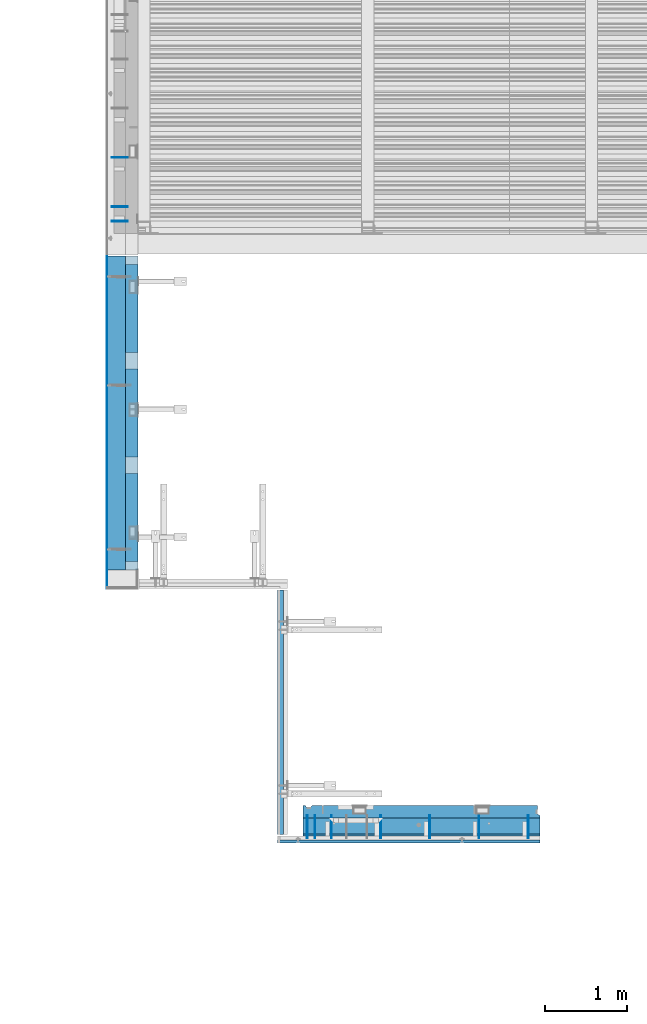
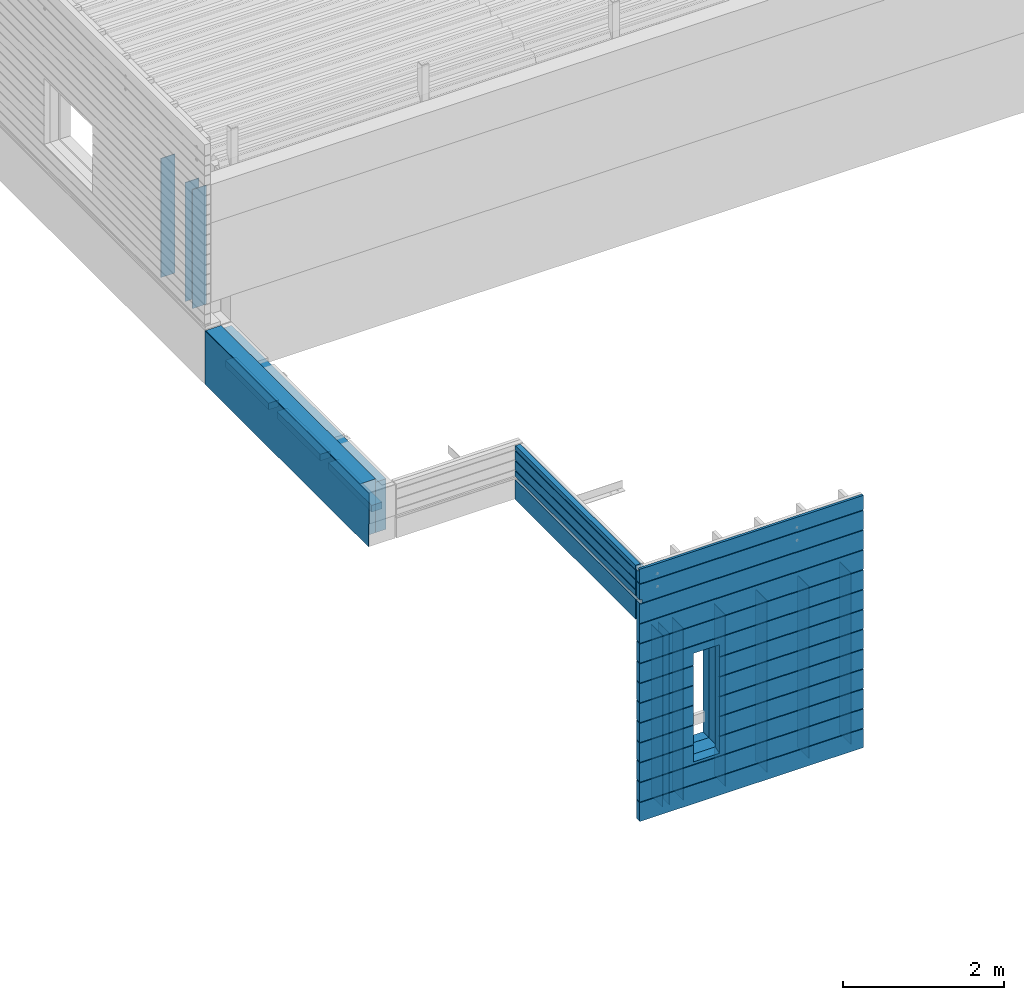
# One storey, part 76 of 153: 20 walls, 5 elements without a shape of their own.
"""IFC2X3 building model written with IfcOpenShell, lengths in millimetres."""

from ifc_helpers import new_model, si_unit, frame, origin_with_axes, place, context, subcontext, project, spatial, faceted_brep, material, type_object, element, aggregate, save


model = new_model("IFC2X3")

# Units and contexts
model_context = context("Model", 3, precision=1e-05, world=origin_with_axes())
body_context = subcontext(model_context, "Body", "Model", "MODEL_VIEW")
ifc_project = project(units=[si_unit("LENGTHUNIT", "METRE", prefix="MILLI"), si_unit("AREAUNIT", "SQUARE_METRE"), si_unit("VOLUMEUNIT", "CUBIC_METRE"), si_unit("MASSUNIT", "GRAM", prefix="KILO"), si_unit("TIMEUNIT", "SECOND"), si_unit("PLANEANGLEUNIT", "RADIAN"), si_unit("SOLIDANGLEUNIT", "STERADIAN"), si_unit("THERMODYNAMICTEMPERATUREUNIT", "DEGREE_CELSIUS"), si_unit("LUMINOUSINTENSITYUNIT", "LUMEN")], contexts=[model_context])

# Site, building, storey
site_placement = place(None, origin_with_axes())
site = spatial("IfcSite", under=ifc_project, at=site_placement, CompositionType="ELEMENT")
building_placement = place(site_placement, origin_with_axes())
building = spatial("IfcBuilding", under=site, at=building_placement, CompositionType="ELEMENT")
storey_placement = place(building_placement, origin_with_axes())
storey = spatial("IfcBuildingStorey", under=building, at=storey_placement, Name="8", CompositionType="ELEMENT", Elevation=0.0)

# Assembly, walls
assembly_1_placement = place(storey_placement, origin_with_axes())
assembly_1 = element("IfcElementAssembly", 1, at=assembly_1_placement, inside=storey, AssemblyPlace="NOTDEFINED", PredefinedType="REINFORCEMENT_UNIT")
ifc_material_1 = material(Name="Undefined")
wall_type_1 = type_object("IfcWallType", PredefinedType="NOTDEFINED")
wall_1_placement = place(assembly_1_placement, frame((7880.0, 15304.39, 104525.0), z_axis=(0.0, 0.0, 1.0), x_axis=(-1.0, 3.00000001838171e-08, 0.0)))
wall_1 = element("IfcWall", 2, at=wall_1_placement, type_object=wall_type_1, material=ifc_material_1, Name="(PD)", context=body_context, shape_type="Brep", body=[
    faceted_brep([(0.0, 5.0, -900.0), (0.0, 5.0, 900.0), (200.0, 5.0, 900.0), (200.0, 5.0, -900.0), (0.0, -5.0, 900.0), (200.0, -5.0, 900.0), (0.0, -5.0, -900.0), (200.0, -5.0, -900.0)], [[[0, 1, 2, 3]], [[1, 4, 5, 2]], [[4, 6, 7, 5]], [[6, 0, 3, 7]], [[5, 7, 3, 2]], [[6, 4, 1, 0]]]),
])
wall_2_placement = place(assembly_1_placement, frame((7880.0, 15904.39, 104525.0), z_axis=(0.0, 0.0, 1.0), x_axis=(-1.0, 3.00000001838171e-08, 0.0)))
wall_2 = element("IfcWall", 3, at=wall_2_placement, type_object=wall_type_1, material=ifc_material_1, Name="(PD)", context=body_context, shape_type="Brep", body=[
    faceted_brep([(0.0, 5.0, -900.0), (0.0, 5.0, 900.0), (200.0, 5.0, 900.0), (200.0, 5.0, -900.0), (0.0, -5.0, 900.0), (200.0, -5.0, 900.0), (0.0, -5.0, -900.0), (200.0, -5.0, -900.0)], [[[0, 1, 2, 3]], [[1, 4, 5, 2]], [[4, 6, 7, 5]], [[6, 0, 3, 7]], [[5, 7, 3, 2]], [[6, 4, 1, 0]]]),
])
wall_3_placement = place(assembly_1_placement, frame((7880.0, 15127.5, 104525.0), z_axis=(0.0, 0.0, 1.0), x_axis=(-1.0, 3.00000001838171e-08, 0.0)))
wall_3 = element("IfcWall", 4, at=wall_3_placement, type_object=wall_type_1, material=ifc_material_1, Name="(PD)", context=body_context, shape_type="Brep", body=[
    faceted_brep([(0.0, 5.0, -900.0), (0.0, 5.0, 900.0), (200.0, 5.0, 900.0), (200.0, 5.0, -900.0), (0.0, -5.0, 900.0), (200.0, -5.0, 900.0), (0.0, -5.0, -900.0), (200.0, -5.0, -900.0)], [[[0, 1, 2, 3]], [[1, 4, 5, 2]], [[4, 6, 7, 5]], [[6, 0, 3, 7]], [[5, 7, 3, 2]], [[6, 4, 1, 0]]]),
])
aggregate(assembly_1, [wall_1, wall_2, wall_3])

assembly_2_placement = place(storey_placement, origin_with_axes())
assembly_2 = element("IfcElementAssembly", 5, at=assembly_2_placement, inside=storey, AssemblyPlace="NOTDEFINED", PredefinedType="REINFORCEMENT_UNIT")
wall_type_2 = type_object("IfcWallType", PredefinedType="NOTDEFINED")
wall_4_placement = place(assembly_2_placement, frame((10162.5, 7880.0, 101115.0), z_axis=(0.0, 0.0, 1.0), x_axis=(0.0, -1.0, 0.0)))
wall_4 = element("IfcWall", 6, at=wall_4_placement, type_object=wall_type_2, material=ifc_material_1, Name="(PD)", context=body_context, shape_type="Brep", body=[
    faceted_brep([(0.0, 5.0, -1300.0), (0.0, 5.0, 1300.0), (280.0, 5.0, 1300.0), (280.0, 5.0, -1300.0), (0.0, -5.0, 1300.0), (280.0, -5.0, 1300.0), (0.0, -5.0, -1300.0), (280.0, -5.0, -1300.0)], [[[0, 1, 2, 3]], [[1, 4, 5, 2]], [[4, 6, 7, 5]], [[6, 0, 3, 7]], [[5, 7, 3, 2]], [[6, 4, 1, 0]]]),
])
wall_5_placement = place(assembly_2_placement, frame((10362.5, 7880.0, 101115.0), z_axis=(0.0, 0.0, 1.0), x_axis=(0.0, -1.0, 0.0)))
wall_5 = element("IfcWall", 7, at=wall_5_placement, type_object=wall_type_2, material=ifc_material_1, Name="(PD)", context=body_context, shape_type="Brep", body=[
    faceted_brep([(0.0, 5.0, -1300.0), (0.0, 5.0, 1300.0), (280.0, 5.0, 1300.0), (280.0, 5.0, -1300.0), (0.0, -5.0, 1300.0), (280.0, -5.0, 1300.0), (0.0, -5.0, -1300.0), (280.0, -5.0, -1300.0)], [[[0, 1, 2, 3]], [[1, 4, 5, 2]], [[4, 6, 7, 5]], [[6, 0, 3, 7]], [[5, 7, 3, 2]], [[6, 4, 1, 0]]]),
])
wall_6_placement = place(assembly_2_placement, frame((10962.5, 7880.0, 101115.0), z_axis=(0.0, 0.0, 1.0), x_axis=(0.0, -1.0, 0.0)))
wall_6 = element("IfcWall", 8, at=wall_6_placement, type_object=wall_type_2, material=ifc_material_1, Name="(PD)", context=body_context, shape_type="Brep", body=[
    faceted_brep([(0.0, 5.0, -1300.0), (0.0, 5.0, 1300.0), (280.0, 5.0, 1300.0), (280.0, 5.0, -1300.0), (0.0, -5.0, 1300.0), (280.0, -5.0, 1300.0), (0.0, -5.0, -1300.0), (280.0, -5.0, -1300.0)], [[[0, 1, 2, 3]], [[1, 4, 5, 2]], [[4, 6, 7, 5]], [[6, 0, 3, 7]], [[5, 7, 3, 2]], [[6, 4, 1, 0]]]),
])
wall_7_placement = place(assembly_2_placement, frame((11562.5, 7880.0, 101115.0), z_axis=(0.0, 0.0, 1.0), x_axis=(0.0, -1.0, 0.0)))
wall_7 = element("IfcWall", 9, at=wall_7_placement, type_object=wall_type_2, material=ifc_material_1, Name="(PD)", context=body_context, shape_type="Brep", body=[
    faceted_brep([(0.0, 5.0, -1300.0), (0.0, 5.0, 1300.0), (280.0, 5.0, 1300.0), (280.0, 5.0, -1300.0), (0.0, -5.0, 1300.0), (280.0, -5.0, 1300.0), (0.0, -5.0, -1300.0), (280.0, -5.0, -1300.0)], [[[0, 1, 2, 3]], [[1, 4, 5, 2]], [[4, 6, 7, 5]], [[6, 0, 3, 7]], [[5, 7, 3, 2]], [[6, 4, 1, 0]]]),
])
wall_8_placement = place(assembly_2_placement, frame((12162.5, 7880.0, 101115.0), z_axis=(0.0, 0.0, 1.0), x_axis=(0.0, -1.0, 0.0)))
wall_8 = element("IfcWall", 10, at=wall_8_placement, type_object=wall_type_2, material=ifc_material_1, Name="(PD)", context=body_context, shape_type="Brep", body=[
    faceted_brep([(0.0, 5.0, -1300.0), (0.0, 5.0, 1300.0), (280.0, 5.0, 1300.0), (280.0, 5.0, -1300.0), (0.0, -5.0, 1300.0), (280.0, -5.0, 1300.0), (0.0, -5.0, -1300.0), (280.0, -5.0, -1300.0)], [[[0, 1, 2, 3]], [[1, 4, 5, 2]], [[4, 6, 7, 5]], [[6, 0, 3, 7]], [[5, 7, 3, 2]], [[6, 4, 1, 0]]]),
])
wall_9_placement = place(assembly_2_placement, frame((12762.5, 7880.0, 101115.0), z_axis=(0.0, 0.0, 1.0), x_axis=(0.0, -1.0, 0.0)))
wall_9 = element("IfcWall", 11, at=wall_9_placement, type_object=wall_type_2, material=ifc_material_1, Name="(PD)", context=body_context, shape_type="Brep", body=[
    faceted_brep([(0.0, 5.0, -1300.0), (0.0, 5.0, 1300.0), (280.0, 5.0, 1300.0), (280.0, 5.0, -1300.0), (0.0, -5.0, 1300.0), (280.0, -5.0, 1300.0), (0.0, -5.0, -1300.0), (280.0, -5.0, -1300.0)], [[[0, 1, 2, 3]], [[1, 4, 5, 2]], [[4, 6, 7, 5]], [[6, 0, 3, 7]], [[5, 7, 3, 2]], [[6, 4, 1, 0]]]),
])
wall_10_placement = place(assembly_2_placement, frame((10065.0, 7880.0, 101115.0), z_axis=(0.0, 0.0, 1.0), x_axis=(0.0, -1.0, 0.0)))
wall_10 = element("IfcWall", 12, at=wall_10_placement, type_object=wall_type_2, material=ifc_material_1, Name="(PD)", context=body_context, shape_type="Brep", body=[
    faceted_brep([(0.0, 5.0, -1300.0), (0.0, 5.0, 1300.0), (280.0, 5.0, 1300.0), (280.0, 5.0, -1300.0), (0.0, -5.0, 1300.0), (280.0, -5.0, 1300.0), (0.0, -5.0, -1300.0), (280.0, -5.0, -1300.0)], [[[0, 1, 2, 3]], [[1, 4, 5, 2]], [[4, 6, 7, 5]], [[6, 0, 3, 7]], [[5, 7, 3, 2]], [[6, 4, 1, 0]]]),
])

# Assemblies, walls
assembly_3_placement = place(storey_placement, origin_with_axes())
assembly_3 = element("IfcElementAssembly", 13, at=assembly_3_placement, inside=storey, AssemblyPlace="NOTDEFINED", PredefinedType="REINFORCEMENT_UNIT")
assembly_4_placement = place(assembly_3_placement, origin_with_axes())
assembly_4 = element("IfcElementAssembly", 14, at=assembly_4_placement, Name="Steel Assembly", AssemblyPlace="NOTDEFINED", PredefinedType="NOTDEFINED")
ifc_material_2 = material()
wall_type_3 = type_object("IfcWallType", PredefinedType="NOTDEFINED")
wall_11_placement = place(assembly_4_placement, frame((7739.99993196853, 10874.9999230972, 103162.5), z_axis=(0.0, 0.0, 1.0), x_axis=(0.0, 1.0, 0.0)))
wall_11 = element("IfcWall", 15, at=wall_11_placement, type_object=wall_type_3, material=ifc_material_2, context=body_context, shape_type="Brep", body=[
    faceted_brep([(0.0, 110.0, -407.5), (0.0, 110.0, 407.5), (3827.00200000092, 109.999999999999, 407.5), (3827.00200000092, 109.999999999999, -407.5), (0.0, -110.0, 407.5), (3827.00200000092, -110.000000000001, 407.5), (0.0, -110.0, -407.5), (3827.00200000092, -110.000000000001, -407.5)], [[[0, 1, 2, 3]], [[1, 4, 5, 2]], [[4, 6, 7, 5]], [[6, 0, 3, 7]], [[5, 7, 3, 2]], [[6, 4, 1, 0]]]),
])
aggregate(assembly_4, [wall_11])
ifc_material_3 = material()
wall_type_4 = type_object("IfcWallType", PredefinedType="NOTDEFINED")
wall_12_placement = place(assembly_3_placement, frame((7624.99999999987, 10644.9998890824, 103162.5), z_axis=(0.0, 0.0, 1.0), x_axis=(0.0, 1.0, 0.0)))
wall_12 = element("IfcWall", 16, at=wall_12_placement, type_object=wall_type_4, material=ifc_material_3, context=body_context, shape_type="Brep", body=[
    faceted_brep([(7.99999704003676, -5.00000236800952, -57.4799999998941), (8.00000000003638, 4.9999976328827, -57.4799999998941), (8.00000000003456, 5.0, -407.5), (7.99999704003494, -5.0, -407.5), (1.81898940354586e-12, -5.00000000000091, -57.4799999998941), (0.0, 4.99999999999909, -57.4799999998941), (0.0, 5.0, 407.5), (0.0, -5.0, 407.5), (4057.0020000009, -5.00000000000091, 407.5), (4057.0020000009, 4.99999999999909, 407.5), (4057.0020000009, -5.00000000000091, -407.5), (4057.0020000009, 4.99999999999909, -407.5)], [[[0, 1, 2, 3]], [[4, 5, 1, 0]], [[6, 7, 8, 9]], [[8, 10, 11, 9]], [[11, 10, 3, 2]], [[6, 9, 11, 2, 1, 5]], [[7, 6, 5, 4]], [[10, 8, 7, 4, 0, 3]]]),
])
ifc_material_4 = material(Name="EPS")
wall_type_5 = type_object("IfcWallType", PredefinedType="NOTDEFINED")
wall_13_placement = place(assembly_3_placement, frame((7924.99993194608, 13525.0, 103055.0), z_axis=(-1.0, 3.00000001838171e-08, 0.0), x_axis=(0.0, 1.0, 0.0)))
wall_13 = element("IfcWall", 17, at=wall_13_placement, type_object=wall_type_5, material=ifc_material_4, context=body_context, shape_type="Brep", body=[
    faceted_brep([(0.0, 50.0, -75.0), (0.0, 50.0, 75.0), (1075.0, 50.0, 75.0), (1075.0, 50.0, -75.0), (0.0, -50.0, 75.0), (1075.0, -50.0, 75.0), (0.0, -50.0, -75.0), (1075.0, -50.0, -75.0)], [[[0, 1, 2, 3]], [[1, 4, 5, 2]], [[4, 6, 7, 5]], [[6, 0, 3, 7]], [[5, 7, 3, 2]], [[6, 4, 1, 0]]]),
])
wall_14_placement = place(assembly_3_placement, frame((7924.99993194608, 12250.0, 103055.0), z_axis=(-1.0, 3.00000001838171e-08, 0.0), x_axis=(0.0, 1.0, 0.0)))
wall_14 = element("IfcWall", 18, at=wall_14_placement, type_object=wall_type_5, material=ifc_material_4, context=body_context, shape_type="Brep", body=[
    faceted_brep([(0.0, 50.0, -75.0), (0.0, 50.0, 75.0), (1075.0, 50.0, 75.0), (1075.0, 50.0, -75.0), (0.0, -50.0, 75.0), (1075.0, -50.0, 75.0), (0.0, -50.0, -75.0), (1075.0, -50.0, -75.0)], [[[0, 1, 2, 3]], [[1, 4, 5, 2]], [[4, 6, 7, 5]], [[6, 0, 3, 7]], [[5, 7, 3, 2]], [[6, 4, 1, 0]]]),
])
wall_15_placement = place(assembly_3_placement, frame((7924.99993194608, 10975.0, 103055.0), z_axis=(-1.0, 3.00000001838171e-08, 0.0), x_axis=(0.0, 1.0, 0.0)))
wall_15 = element("IfcWall", 19, at=wall_15_placement, type_object=wall_type_5, material=ifc_material_4, context=body_context, shape_type="Brep", body=[
    faceted_brep([(0.0, 50.0, -75.0), (0.0, 50.0, 75.0), (1075.0, 50.0, 75.0), (1075.0, 50.0, -75.0), (0.0, -50.0, 75.0), (1075.0, -50.0, 75.0), (0.0, -50.0, -75.0), (1075.0, -50.0, -75.0)], [[[0, 1, 2, 3]], [[1, 4, 5, 2]], [[4, 6, 7, 5]], [[6, 0, 3, 7]], [[5, 7, 3, 2]], [[6, 4, 1, 0]]]),
])

# Assembly, wall
assembly_5_placement = place(storey_placement, origin_with_axes())
assembly_5 = element("IfcElementAssembly", 20, at=assembly_5_placement, inside=storey, AssemblyPlace="NOTDEFINED", PredefinedType="REINFORCEMENT_UNIT")
ifc_material_5 = material(Name="CONCRETE/C30/37")
wall_type_6 = type_object("IfcWallType", PredefinedType="NOTDEFINED")
wall_16_placement = place(assembly_5_placement, frame((9764.99999999999, 7644.99999999999, 103162.5), z_axis=(0.0, 0.0, 1.0), x_axis=(0.0, 1.0, 0.0)))
wall_16 = element("IfcWall", 21, at=wall_16_placement, type_object=wall_type_6, material=ifc_material_5, context=body_context, shape_type="Brep", body=[
    faceted_brep([(2985.0, 60.0, -107.499999999956), (0.0, 60.0, -107.499999999971), (1.81898940354586e-12, 30.0000000000018, -107.499999999971), (2985.0, 30.0000000000018, -107.499999999956), (2985.0, 30.0000000000018, -57.4999999999709), (3.63797880709171e-12, 30.0000000000018, -57.4999999999709), (0.0, 60.0, -57.4999999999709), (2985.0, 60.0, -57.4999999999709), (2550.0, -5.0, -407.5), (2550.0, -5.0, -269.5), (2450.0, -5.0, -269.5), (2450.0, -5.0, -407.5), (2450.0, -60.0, -269.5), (2550.0, -60.0, -269.5), (2450.0, -60.0, -407.5), (550.000000000002, -5.0, -407.5), (550.000000000002, -5.0, -269.5), (450.000000000002, -5.0, -269.5), (450.000000000002, -5.0, -407.5), (550.000000000002, -60.0, -269.5), (550.000000000002, -60.0, -407.5), (450.000000000002, -60.0, -269.5), (450.000000000002, -60.0, -407.5), (0.0, -60.0, -407.5), (0.0, 60.0, -407.5), (2985.0, 60.0, -407.5), (2985.0, -60.0, -407.5), (2550.0, -60.0, -407.5), (2985.00000000001, -60.0000000000146, 357.5), (-9.09494701772928e-12, -60.0000000000073, 357.499999999971), (2985.00000000001, -10.0000000000146, 357.5), (-9.09494701772928e-12, -10.0000000000073, 357.499999999971), (2985.0, -10.0000000000146, 407.5), (0.0, -10.0000000000073, 407.5), (2985.0, 60.0, 407.5), (0.0, 60.0, 407.5), (2985.0, 60.0, 341.999999889245), (0.0, 60.0, 341.999999889245), (2985.0, 49.9999991119166, 340.000000400425), (0.0, 49.9999991119166, 340.000000400425), (2985.0, 49.9999992499179, 329.9999999992), (0.0, 49.9999992499179, 329.9999999992), (2985.0, 60.0, 327.999999944761), (0.0, 60.0, 327.999999944761), (2985.0, 60.0, 191.999999889245), (0.0, 60.0, 191.999999889245), (2985.0, 49.9999991119166, 190.000000400425), (-9.09494701772928e-13, 49.9999991119166, 190.000000400425), (2985.0, 49.9999992499179, 179.9999999992), (-9.09494701772928e-13, 49.9999992499179, 179.9999999992), (2985.0, 60.0, 177.999999944761), (0.0, 60.0, 177.999999944761), (2985.0, 60.0, 41.9999998892454), (0.0, 60.0, 41.9999998892454), (2985.0, 49.9999991119166, 40.0000004004251), (0.0, 49.9999991119166, 40.0000004004251), (2985.0, 49.9999992499179, 29.9999999991996), (0.0, 49.9999992499179, 29.9999999991996), (2985.0, 60.0, 27.9999999447609), (0.0, 60.0, 27.9999999447609)], [[[0, 1, 2, 3]], [[4, 5, 6, 7]], [[3, 2, 5, 4]], [[8, 9, 10, 11]], [[12, 10, 9, 13]], [[14, 11, 10, 12]], [[15, 16, 17, 18]], [[19, 16, 15, 20]], [[21, 17, 16, 19]], [[22, 18, 17, 21]], [[11, 14, 20, 15, 18, 22, 23, 24, 25, 26, 27, 8]], [[13, 9, 8, 27]], [[26, 28, 29, 23, 22, 21, 19, 20, 14, 12, 13, 27]], [[28, 30, 31, 29]], [[32, 33, 31, 30]], [[34, 35, 33, 32]], [[35, 34, 36, 37]], [[38, 39, 37, 36]], [[40, 41, 39, 38]], [[42, 43, 41, 40]], [[43, 42, 44, 45]], [[46, 47, 45, 44]], [[48, 49, 47, 46]], [[50, 51, 49, 48]], [[51, 50, 52, 53]], [[54, 55, 53, 52]], [[56, 57, 55, 54]], [[58, 59, 57, 56]], [[59, 58, 7, 6]], [[1, 24, 23, 29, 31, 33, 35, 37, 39, 41, 43, 45, 47, 49, 51, 53, 55, 57, 59, 6, 5, 2]], [[25, 24, 1, 0]], [[58, 56, 54, 52, 50, 48, 46, 44, 42, 40, 38, 36, 34, 32, 30, 28, 26, 25, 0, 3, 4, 7]]]),
])
aggregate(assembly_5, [wall_16])

# Wall
ifc_material_6 = material(Name="COS5gt")
wall_type_7 = type_object("IfcWallType", PredefinedType="NOTDEFINED")
wall_17_placement = place(assembly_2_placement, frame((12912.5, 7740.0, 101247.5), z_axis=(0.0, 0.0, 1.0), x_axis=(-1.0, 3.00000001838171e-08, 0.0)))
wall_17 = element("IfcWall", 22, at=wall_17_placement, type_object=wall_type_7, material=ifc_material_6, context=body_context, shape_type="Brep", body=[
    faceted_brep([(7.5, 90.0, 1442.5), (2897.5, 90.0, 1442.5), (2897.5, 110.0, 1442.5), (7.5, 110.0, 1442.5), (7.5, 90.0, 1492.5), (2897.5, 90.0, 1492.5), (7.5, -110.0, 1492.5), (2897.5, -110.0, 1492.5), (2897.5, -110.0, -1492.5), (2897.5, 90.0, -1492.5), (2897.5, 90.0, -1442.5), (2897.5, 110.0, -1442.5), (7.5, 110.0, -1442.5), (7.5, 90.0, -1442.5), (2047.50059444406, 110.0, -807.5), (2077.50059444406, 110.0, -807.5), (2427.50059444406, 110.0, -807.5), (2457.50059444406, 110.0, -807.5), (2457.50059444406, 110.0, -802.5), (2457.50059444406, 110.0, 807.5), (2047.50059444406, 110.0, 807.5), (2047.50059444406, 110.0, -802.5), (2041.55464849811, -110.0, -813.445945945947), (2041.55464849811, -110.0, 813.445945945947), (2463.44654039001, -110.0, -813.445945945947), (2463.44654039001, -110.0, 813.445945945947), (7.5, -110.0, -1492.5), (7.5, 90.0, -1492.5)], [[[0, 1, 2, 3]], [[4, 5, 1, 0]], [[6, 7, 5, 4]], [[2, 1, 5, 7, 8, 9, 10, 11]], [[12, 11, 10, 13]], [[3, 2, 11, 12], [14, 15, 16, 17, 18, 19, 20, 21]], [[22, 14, 21, 20, 23]], [[24, 17, 16, 15, 14, 22]], [[18, 17, 24, 25, 19]], [[23, 20, 19, 25]], [[6, 26, 8, 7], [24, 22, 23, 25]], [[8, 26, 27, 9]], [[13, 10, 9, 27]], [[26, 6, 4, 0, 3, 12, 13, 27]]]),
])

ifc_material_7 = material(Name="CONCRETE/C25/30")
wall_type_8 = type_object("IfcWallType", PredefinedType="NOTDEFINED")
wall_18_placement = place(assembly_2_placement, frame((12912.5, 7925.0, 101112.5), z_axis=(0.0, 0.0, 1.0), x_axis=(-1.0, 3.00000001838171e-08, 0.0)))
wall_18 = element("IfcWall", 23, at=wall_18_placement, type_object=wall_type_8, material=ifc_material_7, context=body_context, shape_type="Brep", body=[
    faceted_brep([(2787.5, -75.0, 1357.5), (2787.5, -75.0, -1357.5), (2800.5, -55.0, -1357.5), (2800.5, -55.0, 1357.5), (2852.5, -55.0, 1357.5), (2802.5, -55.0, 1357.5), (2802.5, -55.0, -1357.5), (2852.5, -55.0, -1357.5), (2854.5, -55.0, -1357.5), (2854.5, -55.0, 1357.5), (2867.5, -75.0, -1357.5), (2867.5, -75.0, 1357.5), (2897.5, -75.0, -1357.5), (2897.5, -75.0, 1357.5), (2897.5, 75.0, -1357.5), (2897.5, 75.0, 1357.5), (40.0, -75.0, 1357.5), (7.4999999999709, 75.0, 1357.5), (7.5, 45.0, 1357.5), (40.0, 32.0, 1357.5), (7.4999999999709, 75.0, -1357.5), (7.4999999999709, 45.0, -1357.5), (40.0, 32.0, -1357.5), (40.0, -75.0, -1357.5), (2467.50059444406, -75.0, -682.5), (2037.50059444406, -75.0, -682.5), (2037.50059444406, -75.0, 952.5), (2467.50059444406, -75.0, 952.5), (2463.44654039001, 75.0, -678.445945945947), (2041.55464849811, 75.0, -678.445945945947), (2041.55464849811, 75.0, 948.445945945947), (2463.44654039001, 75.0, 948.445945945947)], [[[0, 1, 2, 3]], [[4, 5, 3, 2, 6, 7, 8, 9]], [[9, 8, 10, 11]], [[12, 13, 11, 10]], [[13, 12, 14, 15]], [[16, 0, 3, 5, 4, 9, 11, 13, 15, 17, 18, 19]], [[17, 20, 21, 18]], [[18, 21, 22, 19]], [[20, 14, 12, 10, 8, 7, 6, 2, 1, 23, 22, 21]], [[16, 19, 22, 23]], [[1, 0, 16, 23], [24, 25, 26, 27]], [[24, 28, 29, 25]], [[25, 29, 30, 26]], [[20, 17, 15, 14], [28, 31, 30, 29]], [[26, 30, 31, 27]], [[28, 24, 27, 31]]]),
])

wall_type_9 = type_object("IfcWallType", PredefinedType="NOTDEFINED")
wall_19_placement = place(assembly_2_placement, frame((12912.5, 7587.5, 101662.5), z_axis=(0.0, 0.0, 1.0), x_axis=(-1.0, 3.00000001838171e-08, 0.0)))
wall_19 = element("IfcWall", 24, at=wall_19_placement, type_object=wall_type_9, material=ifc_material_5, context=body_context, shape_type="Brep", body=[
    faceted_brep([(3207.5, -42.5, 1392.50000000004), (3207.5, 42.5, 1392.50000000003), (3177.50000000002, 42.5000000000036, 1392.50000000003), (3177.50000000002, -42.4999999999964, 1392.50000000004), (3177.50000000002, -42.4999999999964, 1442.50000000003), (3177.50000000002, 42.5000000000018, 1442.50000000003), (3207.5, 42.5, 1442.50000000003), (3207.5, -42.5, 1442.50000000003), (7.4999999999709, -42.5, -1907.5), (7.4999999999709, 42.5, -1907.5), (3207.5, 42.5, -1907.5), (3207.5, -42.5, -1907.5), (7.4999999999709, 42.5, -1622.00000005524), (3207.5, 42.5, -1622.00000005524), (3207.5, -42.5, -1622.00000005524), (3197.49999925017, 32.4999992501671, -1620.00000000079), (3197.49999925017, -42.5, -1620.00000000077), (7.4999999999709, 32.4999992501671, -1620.00000000079), (7.4999999999709, 32.4999991121649, -1609.99999959957), (3197.49999911217, 32.4999991121649, -1609.99999959957), (3197.49999911217, -42.5, -1609.99999959956), (3207.5, -42.5, -1608.00000011075), (3207.5, 42.5, -1608.00000011075), (3207.5, 42.5, -1322.00000005524), (3207.5, -42.5, -1322.00000005524), (7.4999999999709, 42.5, -1608.00000011075), (7.4999999999709, 42.5, -1322.00000005524), (7.4999999999709, 32.4999992501671, -1320.00000000079), (3197.49999925017, 32.4999992501671, -1320.00000000079), (3197.49999925017, -42.5, -1320.00000000077), (3197.49999911217, 32.4999991121649, -1309.99999959957), (3197.49999911217, -42.5, -1309.99999959956), (7.4999999999709, 32.4999991121649, -1309.99999959957), (7.4999999999709, 42.5, -1308.00000011075), (3207.5, 42.5, -1308.00000011075), (3207.5, -42.5, -1308.00000011075), (3207.5, 42.5, -1022.00000005524), (3207.5, -42.5, -1022.00000005524), (3197.49999925017, 32.4999992501671, -1020.00000000079), (3197.49999925017, -42.5, -1020.00000000077), (2437.50059444406, 42.5, -1022.00000005524), (2436.32412376761, 32.4999992501671, -1020.00000000079), (2436.32412375137, 32.4999991121649, -1009.99999959957), (3197.49999911217, 32.4999991121649, -1009.99999959957), (3197.49999911217, -42.5, -1009.99999959956), (3207.5, 42.5, -1008.00000011075), (3207.5, -42.5, -1008.00000011075), (2437.50059444406, 42.5, -1008.00000011075), (3207.5, 42.5, -722.000000055239), (2437.50059444406, 42.5, -722.000000055239), (3207.5, -42.5, -722.000000055239), (3197.49999925017, 32.4999992501671, -720.000000000786), (3197.49999925017, -42.5, -720.000000000771), (2436.32412376761, 32.4999992501671, -720.000000000786), (2436.32412375137, 32.4999991121649, -709.999999599575), (3197.49999911217, 32.4999991121649, -709.999999599575), (3197.49999911217, -42.5, -709.99999959956), (3207.5, 42.5, -708.000000110755), (3207.5, -42.5, -708.000000110755), (2437.50059444406, 42.5, -708.000000110755), (3207.5, 42.5, -422.000000055239), (2437.50059444406, 42.5, -422.000000055239), (3207.5, -42.5, -422.000000055239), (3197.49999925017, 32.4999992501671, -420.000000000786), (3197.49999925017, -42.5, -420.000000000771), (2436.32412376761, 32.4999992501671, -420.000000000786), (2436.32412375137, 32.4999991121649, -409.999999599575), (3197.49999911217, 32.4999991121649, -409.999999599575), (3197.49999911217, -42.5, -409.99999959956), (3207.5, 42.5, -408.000000110755), (3207.5, -42.5, -408.000000110755), (2437.50059444406, 42.5, -408.000000110755), (3207.5, 42.5, -122.000000055239), (2437.50059444406, 42.5, -122.000000055239), (3207.5, -42.5, -122.000000055239), (3197.49999925017, 32.4999992501671, -120.000000000786), (3197.49999925017, -42.5, -120.000000000771), (2436.32412376761, 32.4999992501671, -120.000000000786), (2436.32412375137, 32.4999991121649, -109.999999599575), (3197.49999911217, 32.4999991121649, -109.999999599575), (3197.49999911217, -42.5, -109.99999959956), (3207.5, -42.5, -108.000000110755), (3207.5, 42.5, -108.000000110755), (3207.5, 42.5, 177.999999944761), (3207.5, -42.5, 177.999999944761), (2437.50059444406, 42.5, -108.000000110755), (2437.50059444406, 42.5, 177.999999944761), (2436.32412376761, 32.4999992501671, 179.999999999214), (3197.49999925017, 32.4999992501671, 179.999999999214), (3197.49999925017, -42.5, 179.999999999229), (3197.49999911217, 32.4999991121649, 190.000000400425), (3197.49999911217, -42.5, 190.00000040044), (2436.32412375137, 32.4999991121649, 190.000000400425), (2437.50059444406, 42.5, 191.999999889245), (3207.5, 42.5, 191.999999889245), (3207.5, -42.5, 191.999999889245), (3207.5, 42.5, 477.999999944761), (3207.5, -42.5, 477.999999944761), (3197.49999925017, 32.4999992501671, 479.999999999214), (3197.49999925017, -42.5, 479.999999999229), (7.4999999999709, 42.5, 477.999999944761), (7.49999999998181, 32.4999992501671, 479.999999999214), (7.49999999998181, 32.4999991121649, 490.000000400425), (3197.49999911217, 32.4999991121649, 490.000000400425), (3197.49999911217, -42.5, 490.00000040044), (3207.5, 42.5, 491.999999889245), (3207.5, -42.5, 491.999999889245), (7.4999999999709, 42.5, 491.999999889245), (7.4999999999709, 42.5, 777.999999944761), (3207.5, 42.5, 777.999999944761), (3207.5, -42.5, 777.999999944761), (3197.49999925017, 32.4999992501671, 779.999999999214), (3197.49999925017, -42.5, 779.999999999229), (7.49999999998363, 32.4999992501671, 779.999999999214), (7.49999999998363, 32.4999991121649, 790.000000400425), (3197.49999911217, 32.4999991121649, 790.000000400425), (3197.49999911217, -42.5, 790.00000040044), (3207.5, -42.5, 791.999999889245), (3207.5, 42.5, 791.999999889245), (3207.5, 42.5, 1077.99999994476), (3207.5, 32.4999992501671, 1079.99999999921), (3207.5, 32.4999991121649, 1090.00000040043), (3207.5, 42.5, 1091.99999988925), (3207.5, 42.5, 1377.99999994476), (3207.5, 32.4999992501671, 1379.99999999921), (3207.5, 32.4999991121649, 1390.00000040043), (3207.5, 42.5, 1391.99999988925), (7.4999999999709, 42.5, 791.999999889245), (7.4999999999709, 42.5, 1077.99999994476), (7.49999999998545, 32.4999992501671, 1079.99999999921), (7.49999999998545, 32.4999991121649, 1090.00000040043), (7.4999999999709, 42.5, 1091.99999988925), (7.4999999999709, 42.5, 1377.99999994476), (7.49999999998545, 32.4999992501671, 1379.99999999921), (7.49999999998545, 32.4999991121649, 1390.00000040043), (7.4999999999709, 42.5, 1391.99999988925), (7.4999999999709, 42.5, 1677.99999994476), (3207.5, 42.5, 1677.99999994476), (3207.5, -42.5, 1677.99999994476), (3197.49999925017, 32.4999992501671, 1679.99999999921), (3197.49999925017, -42.5, 1679.99999999923), (7.49999999998727, 32.4999992501671, 1679.99999999921), (7.49999999998727, 32.4999991121649, 1690.00000040043), (3197.49999911217, 32.4999991121649, 1690.00000040043), (3197.49999911217, -42.5, 1690.00000040044), (3207.5, 42.5, 1691.99999988925), (3207.5, -42.5, 1691.99999988925), (7.4999999999709, 42.5, 1691.99999988925), (7.4999999999709, 42.5, 1907.5), (3207.5, 42.5, 1907.5), (7.4999999999709, 7.5, 1907.5), (3207.5, 7.5, 1907.5), (3207.5, 7.5, 1857.5), (3207.5, -42.5, 1857.5), (7.5, 7.5, 1857.5), (7.5, -42.5, 1857.5), (7.4999999999709, 42.5, 191.999999889245), (7.49999999997817, 32.4999991121649, 190.000000400425), (7.49999999997817, 32.4999992501671, 179.999999999214), (7.4999999999709, 42.5, 177.999999944761), (7.4999999999709, 42.5, -108.000000110755), (7.49999999997453, 32.4999991121649, -109.999999599575), (7.49999999997453, 32.4999992501671, -120.000000000786), (7.4999999999709, 42.5, -122.000000055239), (7.4999999999709, 42.5, -408.000000110755), (7.4999999999709, 32.4999991121649, -409.999999599575), (7.4999999999709, 32.4999992501671, -420.000000000786), (7.4999999999709, 42.5, -422.000000055239), (7.4999999999709, 42.5, -708.000000110755), (7.4999999999709, 32.4999991121649, -709.999999599575), (7.4999999999709, 32.4999992501671, -720.000000000786), (7.4999999999709, 42.5, -722.000000055239), (7.4999999999709, 42.5, -1008.00000011075), (7.49999999997272, 32.4999991121649, -1009.99999959957), (7.49999999997272, 32.4999992501671, -1020.00000000079), (7.4999999999709, 42.5, -1022.00000005524), (2068.67706513675, 32.4999991121649, 190.000000400425), (2068.67706512051, 32.4999992501671, 179.999999999214), (2067.50059444406, 42.5, 177.999999944761), (2067.50059444406, 42.5, -108.000000110755), (2068.67706513675, 32.4999991121649, -109.999999599575), (2068.67706512051, 32.4999992501671, -120.000000000786), (2067.50059444406, 42.5, -122.000000055239), (2067.50059444406, 42.5, -408.000000110755), (2068.67706513675, 32.4999991121649, -409.999999599575), (2068.67706512051, 32.4999992501671, -420.000000000786), (2067.50059444406, 42.5, -422.000000055239), (2067.50059444406, 42.5, -708.000000110755), (2068.67706513675, 32.4999991121649, -709.999999599575), (2068.67706512051, 32.4999992501671, -720.000000000786), (2067.50059444406, 42.5, -722.000000055239), (2067.50059444406, 42.5, -1008.00000011075), (2068.67706513675, 32.4999991121649, -1009.99999959957), (2068.67706512051, 32.4999992501671, -1020.00000000079), (2067.50059444406, 42.5, -1022.00000005524), (2437.50059444406, 42.5, -1272.5), (2067.50059444406, 42.5, -1272.5), (2077.50059444406, -42.5, -1222.5), (2427.50059444406, -42.5, -1222.5), (2427.50059444406, -42.5, 367.5), (2427.50059444406, -42.5, 372.5), (2437.50059444406, 42.5, 367.5), (2427.50059444406, 42.5, 367.5), (2077.50059444406, 42.5, 367.5), (2067.50059444406, 42.5, 367.5), (2067.50059444406, 42.5, 191.999999889245), (2077.50059444406, -42.5, 372.5), (2077.50059444406, -42.5, 367.5)], [[[0, 1, 2, 3]], [[4, 5, 6, 7]], [[3, 2, 5, 4]], [[8, 9, 10, 11]], [[10, 9, 12, 13]], [[11, 10, 13, 14]], [[14, 13, 15, 16]], [[12, 17, 15, 13]], [[17, 18, 19, 15]], [[16, 15, 19, 20]], [[21, 22, 23, 24]], [[20, 19, 22, 21]], [[18, 25, 22, 19]], [[22, 25, 26, 23]], [[26, 27, 28, 23]], [[24, 23, 28, 29]], [[29, 28, 30, 31]], [[27, 32, 30, 28]], [[32, 33, 34, 30]], [[31, 30, 34, 35]], [[35, 34, 36, 37]], [[37, 36, 38, 39]], [[40, 41, 38, 36]], [[41, 42, 43, 38]], [[39, 38, 43, 44]], [[44, 43, 45, 46]], [[42, 47, 45, 43]], [[48, 45, 47, 49]], [[46, 45, 48, 50]], [[50, 48, 51, 52]], [[49, 53, 51, 48]], [[53, 54, 55, 51]], [[52, 51, 55, 56]], [[56, 55, 57, 58]], [[54, 59, 57, 55]], [[60, 57, 59, 61]], [[58, 57, 60, 62]], [[62, 60, 63, 64]], [[61, 65, 63, 60]], [[65, 66, 67, 63]], [[64, 63, 67, 68]], [[68, 67, 69, 70]], [[66, 71, 69, 67]], [[72, 69, 71, 73]], [[70, 69, 72, 74]], [[74, 72, 75, 76]], [[73, 77, 75, 72]], [[77, 78, 79, 75]], [[76, 75, 79, 80]], [[81, 82, 83, 84]], [[80, 79, 82, 81]], [[78, 85, 82, 79]], [[83, 82, 85, 86]], [[86, 87, 88, 83]], [[84, 83, 88, 89]], [[89, 88, 90, 91]], [[87, 92, 90, 88]], [[92, 93, 94, 90]], [[91, 90, 94, 95]], [[95, 94, 96, 97]], [[97, 96, 98, 99]], [[100, 101, 98, 96]], [[101, 102, 103, 98]], [[99, 98, 103, 104]], [[104, 103, 105, 106]], [[102, 107, 105, 103]], [[105, 107, 108, 109]], [[106, 105, 109, 110]], [[110, 109, 111, 112]], [[108, 113, 111, 109]], [[113, 114, 115, 111]], [[112, 111, 115, 116]], [[117, 118, 119, 120, 121, 122, 123, 124, 125, 126, 1, 0]], [[116, 115, 118, 117]], [[114, 127, 118, 115]], [[118, 127, 128, 119]], [[129, 120, 119, 128]], [[130, 121, 120, 129]], [[131, 122, 121, 130]], [[122, 131, 132, 123]], [[133, 124, 123, 132]], [[134, 125, 124, 133]], [[135, 126, 125, 134]], [[1, 126, 135, 136, 137, 6, 5, 2]], [[137, 138, 7, 6]], [[138, 137, 139, 140]], [[136, 141, 139, 137]], [[141, 142, 143, 139]], [[140, 139, 143, 144]], [[144, 143, 145, 146]], [[142, 147, 145, 143]], [[148, 149, 145, 147]], [[149, 148, 150, 151]], [[146, 145, 149, 151, 152, 153]], [[150, 154, 152, 151]], [[155, 153, 152, 154]], [[150, 148, 147, 142, 141, 136, 135, 134, 133, 132, 131, 130, 129, 128, 127, 114, 113, 108, 107, 102, 101, 100, 156, 157, 158, 159, 160, 161, 162, 163, 164, 165, 166, 167, 168, 169, 170, 171, 172, 173, 174, 175, 33, 32, 27, 26, 25, 18, 17, 12, 9, 8, 155, 154]], [[158, 157, 176, 177]], [[159, 158, 177, 178]], [[160, 159, 178, 179]], [[161, 160, 179, 180]], [[162, 161, 180, 181]], [[163, 162, 181, 182]], [[164, 163, 182, 183]], [[165, 164, 183, 184]], [[166, 165, 184, 185]], [[167, 166, 185, 186]], [[168, 167, 186, 187]], [[169, 168, 187, 188]], [[170, 169, 188, 189]], [[171, 170, 189, 190]], [[172, 171, 190, 191]], [[173, 172, 191, 192]], [[174, 173, 192, 193]], [[175, 174, 193, 194]], [[195, 40, 36, 34, 33, 175, 194, 196]], [[196, 197, 198, 195]], [[199, 200, 201, 93, 92, 87, 86, 85, 78, 77, 73, 71, 66, 65, 61, 59, 54, 53, 49, 47, 42, 41, 40, 195, 198]], [[156, 100, 96, 94, 93, 201, 202, 203, 204, 205]], [[157, 156, 205, 176]], [[204, 206, 207, 197, 196, 194, 193, 192, 191, 190, 189, 188, 187, 186, 185, 184, 183, 182, 181, 180, 179, 178, 177, 176, 205]], [[203, 202, 201, 200, 206, 204]], [[138, 140, 144, 146, 153, 155, 8, 11, 14, 16, 20, 21, 24, 29, 31, 35, 37, 39, 44, 46, 50, 52, 56, 58, 62, 64, 68, 70, 74, 76, 80, 81, 84, 89, 91, 95, 97, 99, 104, 106, 110, 112, 116, 117, 0, 3, 4, 7], [199, 198, 197, 207, 206, 200]]]),
])

aggregate(assembly_2, [wall_4, wall_5, wall_6, wall_7, wall_8, wall_9, wall_10, wall_19, wall_17, wall_18])

wall_type_10 = type_object("IfcWallType", PredefinedType="NOTDEFINED")
wall_20_placement = place(assembly_3_placement, frame((7924.9999319686, 10874.9999778166, 103137.5), z_axis=(0.0, 0.0, 1.0), x_axis=(0.0, 1.0, 0.0)))
wall_20 = element("IfcWall", 25, at=wall_20_placement, type_object=wall_type_10, material=ifc_material_7, context=body_context, shape_type="Brep", body=[
    faceted_brep([(3724.99999998328, -75.0011025774902, -132.499999999971), (3725.00004438328, 74.9988974225034, -132.499999999971), (2650.00004438332, 74.9992156225035, -132.499999999971), (2649.99999998332, -75.0007843774902, -132.499999999971), (2650.00004438332, 74.9992156225035, -32.4999999999709), (2649.99999998332, -75.0007843774902, -32.4999999999709), (3725.00004438328, 74.9988974225034, -32.4999999999709), (3724.99999998328, -75.0011025774902, -32.4999999999709), (-3.63797880709171e-12, 75.0000000000036, 382.5), (0.0, -75.0, 382.5), (3827.00199719917, -75.0, 382.5), (3827.00199719917, 74.9999999999991, 382.5), (0.0, -75.0, -382.5), (-3.63797880709171e-12, 75.0000000000036, -382.5), (3827.00199719917, 74.9999999999991, -382.5), (3827.00199719917, -75.0, -382.5), (99.999999984233, -75.0000345059671, -32.5), (100.000048134232, 74.9999654940257, -32.5), (1175.00004438339, 74.9996522225038, -32.4999999999709), (1174.99999998339, -75.0003477774899, -32.4999999999709), (99.999999984233, -75.0000345059671, -132.5), (100.000048134232, 74.9999654940257, -132.5), (1174.99999998339, -75.0003477774899, -132.499999999971), (1175.00004438339, 74.9996522225038, -132.499999999971), (1374.99999998338, -75.0004069774905, -132.499999999971), (1374.99999998338, -75.0004069774905, -32.4999999999709), (2449.99999998333, -75.0007251774905, -32.4999999999709), (2449.99999998333, -75.0007251774905, -132.499999999971), (1375.00004438338, 74.9995930225032, -132.499999999971), (1375.00004438338, 74.9995930225032, -32.4999999999709), (2450.00004438333, 74.9992748225031, -132.499999999971), (2450.00004438333, 74.9992748225031, -32.4999999999709)], [[[0, 1, 2, 3]], [[3, 2, 4, 5]], [[5, 4, 6, 7]], [[7, 6, 1, 0]], [[8, 9, 10, 11]], [[12, 9, 8, 13]], [[12, 13, 14, 15]], [[10, 15, 14, 11]], [[16, 17, 18, 19]], [[17, 16, 20, 21]], [[22, 23, 21, 20]], [[19, 18, 23, 22]], [[9, 12, 15, 10], [3, 5, 7, 0], [24, 25, 26, 27], [20, 16, 19, 22]], [[24, 28, 29, 25]], [[27, 30, 28, 24]], [[26, 31, 30, 27]], [[25, 29, 31, 26]], [[13, 8, 11, 14], [2, 1, 6, 4], [28, 30, 31, 29], [21, 23, 18, 17]]]),
])

aggregate(assembly_3, [wall_13, wall_14, wall_15, wall_12, assembly_4, wall_20])

save(model, "model.ifc")
